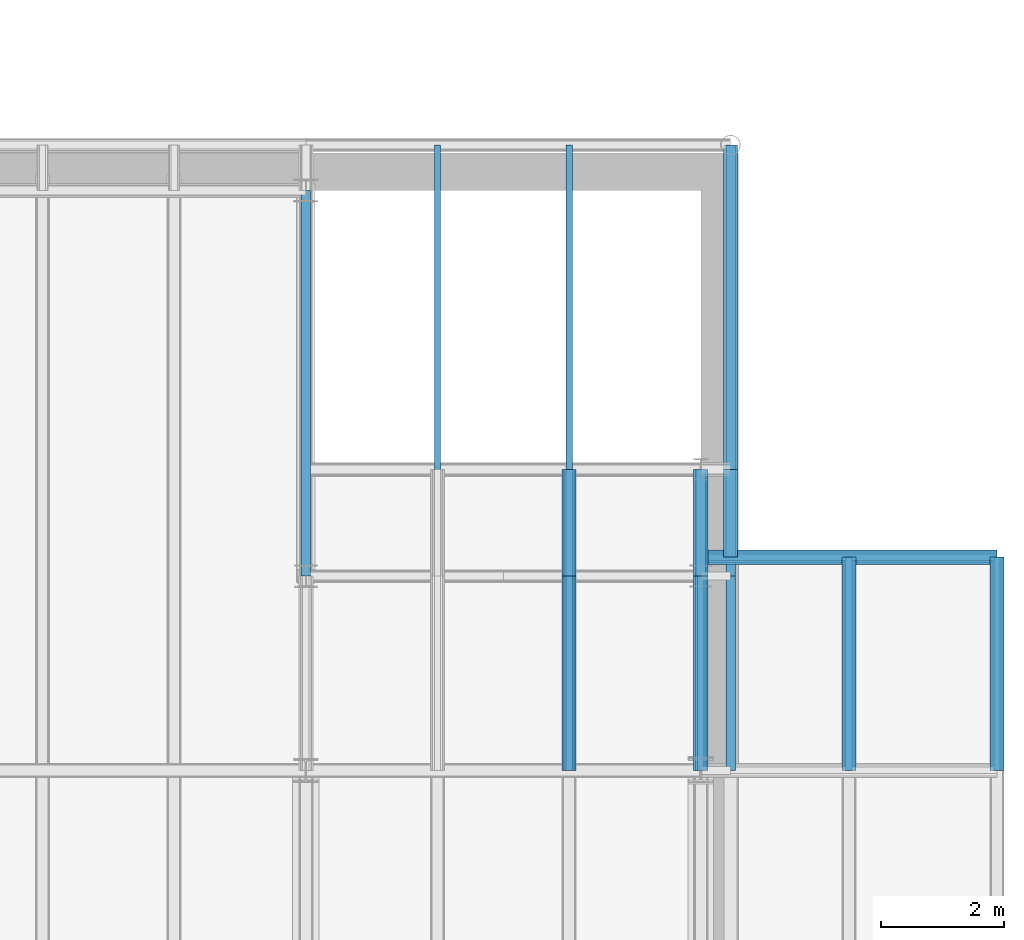
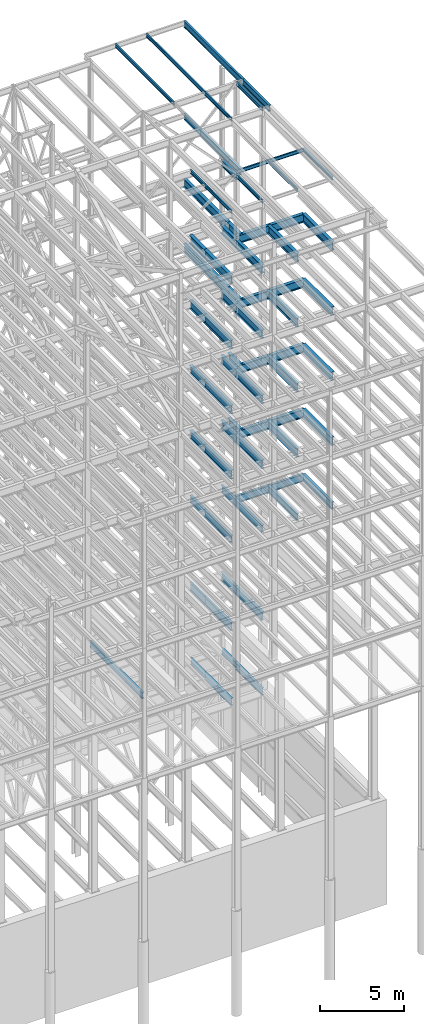
# One storey, part 147 of 150: 65 beams.
"""IFC2X3 building model written with IfcOpenShell, lengths in millimetres."""

import ifcopenshell
import ifcopenshell.guid

model = None  # the IFC model being written
_history = None  # IfcOwnerHistory: only IFC2X3 demands one
_inside = {}  # id of a spatial element -> (the spatial element, [elements in it])
_under = {}  # id of a project, library or spatial element -> (it, [spatial elements below it])
_declared = {}  # id of a project -> (the project, [libraries it declares])
_typed = {}  # id of a type object -> (the type object, [elements of that type])
_made_of = {}  # id of a material, layer set ... -> (it, [elements and type objects made of it])


def new_model(schema):
    """Start an empty IFC model of exactly this schema.

    Asked for "IFC4X3", IfcOpenShell would pick the latest addendum, in which some entities
    have other attributes; the version numbers below select the first issue.
    IFC2X3 requires an IfcOwnerHistory on every rooted entity: one is made here for all.
    """
    global model, _history
    if schema == "IFC4X3":
        model = ifcopenshell.file(schema_version=(4, 3, 0, 0))
    else:
        model = ifcopenshell.file(schema=schema)
    _inside.clear()
    _under.clear()
    _declared.clear()
    _typed.clear()
    _made_of.clear()
    _history = None
    if model.schema == "IFC2X3":
        org = make("IfcOrganization", Name="unknown")
        user = make(
            "IfcPersonAndOrganization",
            ThePerson=make("IfcPerson", FamilyName="unknown"),
            TheOrganization=org,
        )
        app = make(
            "IfcApplication",
            ApplicationDeveloper=org,
            Version="unknown",
            ApplicationFullName="unknown",
            ApplicationIdentifier="unknown",
        )
        _history = make(
            "IfcOwnerHistory",
            OwningUser=user,
            OwningApplication=app,
            ChangeAction="ADDED",
            CreationDate=0,
        )
    return model


def make(cls, **values):
    """One entity of the class cls with the attributes given. An attribute that is None is left unset."""
    return model.create_entity(
        cls, **{name: value for name, value in values.items() if value is not None}
    )


def rooted(cls, **values):
    """An entity with a GlobalId (a new one), such as an element, a storey or a relation."""
    return make(cls, GlobalId=ifcopenshell.guid.new(), OwnerHistory=_history, **values)


def si_unit(unit_type, name, prefix=None):
    """IfcSIUnit, for example si_unit("LENGTHUNIT", "METRE", prefix="MILLI")."""
    return make("IfcSIUnit", UnitType=unit_type, Prefix=prefix, Name=name)


def assignment(units):
    """IfcUnitAssignment: the units of a project."""
    return None if units is None else make("IfcUnitAssignment", Units=units)


def point(xyz):
    """IfcCartesianPoint."""
    return None if xyz is None else make("IfcCartesianPoint", Coordinates=xyz)


def direction(xyz):
    """IfcDirection."""
    return None if xyz is None else make("IfcDirection", DirectionRatios=xyz)


def frame(location, z_axis=None, x_axis=None):
    """IfcAxis2Placement3D, a coordinate frame: its origin and axes. An axis left out is left unset."""
    return make(
        "IfcAxis2Placement3D",
        Location=point(location),
        Axis=direction(z_axis),
        RefDirection=direction(x_axis),
    )


def frame_2d(location, x_axis=None):
    """IfcAxis2Placement2D, a coordinate frame in the plane: its origin and x axis."""
    return make(
        "IfcAxis2Placement2D", Location=point(location), RefDirection=direction(x_axis)
    )


def origin_with_axes():
    """The frame at (0, 0, 0) with the z axis (0, 0, 1) and the x axis (1, 0, 0) written out."""
    return frame((0.0, 0.0, 0.0), z_axis=(0.0, 0.0, 1.0), x_axis=(1.0, 0.0, 0.0))


def origin_2d_with_axis():
    """The frame at (0, 0) in the plane with the x axis (1, 0) written out."""
    return frame_2d((0.0, 0.0), x_axis=(1.0, 0.0))


def place(relative_to, where):
    """IfcLocalPlacement: puts the frame where relative to a parent placement (None: the world)."""
    return make(
        "IfcLocalPlacement", PlacementRelTo=relative_to, RelativePlacement=where
    )


def context(
    kind, dimensions, precision=None, world=None, true_north=None, identifier=None
):
    """IfcGeometricRepresentationContext, for example the 3D "Model" context."""
    return make(
        "IfcGeometricRepresentationContext",
        ContextIdentifier=identifier,
        ContextType=kind,
        CoordinateSpaceDimension=dimensions,
        Precision=precision,
        WorldCoordinateSystem=world,
        TrueNorth=true_north,
    )


def subcontext(parent, identifier, kind, view, scale=None):
    """IfcGeometricRepresentationSubContext, for example "Body" below "Model"."""
    return make(
        "IfcGeometricRepresentationSubContext",
        ContextIdentifier=identifier,
        ContextType=kind,
        ParentContext=parent,
        TargetScale=scale,
        TargetView=view,
    )


def project(units=None, contexts=None):
    """IfcProject with its units and contexts."""
    return rooted(
        "IfcProject",
        Name="project",
        RepresentationContexts=contexts,
        UnitsInContext=assignment(units),
    )


def spatial(cls, under=None, at=None, **own):
    """A site, building, storey or space (cls), placed at a placement, below another one or the project."""
    s = rooted(cls, ObjectPlacement=at, **own)
    if under is not None:
        _under.setdefault(under.id(), (under, []))[1].append(s)
    return s


def profile(cls, at=None, kind="AREA", **sizes):
    """A parametric profile (cls). Its sizes go by their IFC names, for example OverallWidth=200.0."""
    return make(cls, ProfileType=kind, Position=at, **sizes)


def i_section(**sizes):
    """IfcIShapeProfileDef."""
    return profile("IfcIShapeProfileDef", **sizes)


def extrude(swept, where, along, depth):
    """IfcExtrudedAreaSolid: the profile swept, set in the frame where, extruded along a direction by depth."""
    return make(
        "IfcExtrudedAreaSolid",
        SweptArea=swept,
        Position=where,
        ExtrudedDirection=direction(along),
        Depth=depth,
    )


def shape(context_of_items, identifier, shape_type, items):
    """IfcShapeRepresentation: the items that make up one representation, for example the "Body"."""
    return make(
        "IfcShapeRepresentation",
        ContextOfItems=context_of_items,
        RepresentationIdentifier=identifier,
        RepresentationType=shape_type,
        Items=items,
    )


def material(Name=None, Category=None):
    """IfcMaterial."""
    return make("IfcMaterial", Name=Name, Category=Category)


def made_of(thing, what):
    """Note that an element or type object is made of a material, layer set ...; save() writes the relation."""
    if what is not None:
        _made_of.setdefault(what.id(), (what, []))[1].append(thing)
    return thing


def type_object(cls, material=None, **own):
    """A type object (cls), such as IfcWallType, which elements share."""
    return made_of(rooted(cls, **own), material)


def element(
    cls,
    number,
    at=None,
    inside=None,
    cuts=None,
    type_object=None,
    material=None,
    context=None,
    identifier="Body",
    shape_type=None,
    held_by="IfcProductDefinitionShape",
    body=None,
    shapes=None,
    **own,
):
    """One element of the class cls, such as IfcWall. Its Tag is "e" and its number.

    at: its placement. inside: the storey or other place that contains it. cuts: it is an
    opening in that element (IfcRelVoidsElement). A single representation is given by context,
    identifier, shape_type and body (its items); several are given by shapes. held_by: the class
    of the entity that holds the representations. save() writes the other relations.
    """
    e = rooted(cls, Tag="e%d" % number, ObjectPlacement=at, **own)
    if body is not None:
        shapes = [shape(context, identifier, shape_type, body)]
    if shapes is not None:
        e.Representation = make(held_by, Representations=shapes)
    if inside is not None:
        _inside.setdefault(inside.id(), (inside, []))[1].append(e)
    if cuts is not None:
        rooted(
            "IfcRelVoidsElement", RelatingBuildingElement=cuts, RelatedOpeningElement=e
        )
    if type_object is not None:
        _typed.setdefault(type_object.id(), (type_object, []))[1].append(e)
    return made_of(e, material)


def aggregate(whole, parts):
    """IfcRelAggregates: a whole, such as a stair, and the parts it consists of."""
    return rooted("IfcRelAggregates", RelatingObject=whole, RelatedObjects=parts)


def save(model, path):
    """Write the relations noted so far, then the file.

    IfcRelAggregates (storeys below a building ...), IfcRelContainedInSpatialStructure (elements
    in a storey), IfcRelDefinesByType, IfcRelAssociatesMaterial and IfcRelDeclares: one each for
    every whole, place, type object, material and project.
    """
    for whole, parts in _under.values():
        aggregate(whole, parts)
    for where, things in _inside.values():
        rooted(
            "IfcRelContainedInSpatialStructure",
            RelatedElements=things,
            RelatingStructure=where,
        )
    for kind, things in _typed.values():
        rooted("IfcRelDefinesByType", RelatedObjects=things, RelatingType=kind)
    for what, things in _made_of.values():
        rooted("IfcRelAssociatesMaterial", RelatedObjects=things, RelatingMaterial=what)
    for by, libraries in _declared.values():
        rooted("IfcRelDeclares", RelatingContext=by, RelatedDefinitions=libraries)
    model.write(path)


model = new_model("IFC2X3")

# Units and contexts
model_context = context("Model", 3, precision=1e-05, world=origin_with_axes())
body_context = subcontext(model_context, "Body", "Model", "MODEL_VIEW")
ifc_project = project(units=[si_unit("LENGTHUNIT", "METRE", prefix="MILLI"), si_unit("AREAUNIT", "SQUARE_METRE"), si_unit("VOLUMEUNIT", "CUBIC_METRE"), si_unit("MASSUNIT", "GRAM", prefix="KILO"), si_unit("TIMEUNIT", "SECOND"), si_unit("PLANEANGLEUNIT", "RADIAN"), si_unit("SOLIDANGLEUNIT", "STERADIAN"), si_unit("THERMODYNAMICTEMPERATUREUNIT", "DEGREE_CELSIUS"), si_unit("LUMINOUSINTENSITYUNIT", "LUMEN")], contexts=[model_context])

# Site, building, storey
site_placement = place(None, origin_with_axes())
site = spatial("IfcSite", under=ifc_project, at=site_placement, CompositionType="ELEMENT")
building_placement = place(site_placement, origin_with_axes())
building = spatial("IfcBuilding", under=site, at=building_placement, Name="Undefined", CompositionType="ELEMENT")
storey_placement = place(building_placement, origin_with_axes())
storey = spatial("IfcBuildingStorey", under=building, at=storey_placement, Name="Undefined", CompositionType="ELEMENT", Elevation=0.0)

# Beams
ifc_material = material(Name="STEEL/A992")
beam_type_1 = type_object("IfcBeamType", Name="W18X35", PredefinedType="NOTDEFINED")
beam_1_placement = place(storey_placement, frame((89077.8, 25628.6, 65687.575), z_axis=(0.0, 0.0, 1.0), x_axis=(0.0, -1.0, 0.0)))
element("IfcBeam", 1, at=beam_1_placement, inside=storey, type_object=beam_type_1, material=ifc_material, Name="BEAM", ObjectType="W18X35", context=body_context, shape_type="SweptSolid", body=[
    extrude(i_section(OverallWidth=152.4, OverallDepth=450.85, WebThickness=7.9375, FlangeThickness=10.795, FilletRadius=17.78, at=origin_2d_with_axis()), frame((3149.59999999999, 0.0, 0.0), z_axis=(-1.0, 0.0, 0.0), x_axis=(0.0, -1.0, 0.0)), (0.0, 0.0, 1.0), 3149.59999999999),
])
beam_2_placement = place(storey_placement, frame((89077.8, 25628.6, 65687.575), z_axis=(0.0, 0.0, 1.0), x_axis=(0.0, 1.0, 0.0)))
element("IfcBeam", 2, at=beam_2_placement, inside=storey, type_object=beam_type_1, material=ifc_material, Name="BEAM", ObjectType="W18X35", context=body_context, shape_type="SweptSolid", body=[
    extrude(i_section(OverallWidth=152.4, OverallDepth=450.85, WebThickness=7.9375, FlangeThickness=10.795, FilletRadius=17.78, at=origin_2d_with_axis()), frame((6985.0, 0.0, 0.0), z_axis=(-1.0, 0.0, 0.0), x_axis=(0.0, -1.0, 0.0)), (0.0, 0.0, 1.0), 6985.0),
])
beam_3_placement = place(storey_placement, frame((88595.2, 25628.6, 58981.975), z_axis=(0.0, 0.0, 1.0), x_axis=(0.0, 1.0, 0.0)))
element("IfcBeam", 3, at=beam_3_placement, inside=storey, type_object=beam_type_1, material=ifc_material, Name="BEAM", ObjectType="W18X35", context=body_context, shape_type="SweptSolid", body=[
    extrude(i_section(OverallWidth=152.4, OverallDepth=450.85, WebThickness=7.9375, FlangeThickness=10.795, FilletRadius=17.78, at=origin_2d_with_axis()), frame((1727.2, 0.0, 0.0), z_axis=(-1.0, 0.0, 0.0), x_axis=(0.0, -1.0, 0.0)), (0.0, 0.0, 1.0), 1727.2),
])
beam_4_placement = place(storey_placement, frame((89077.8, 27355.8, 58981.975), z_axis=(0.0, 0.0, 1.0), x_axis=(0.0, -1.0, 0.0)))
element("IfcBeam", 4, at=beam_4_placement, inside=storey, type_object=beam_type_1, material=ifc_material, Name="BEAM", ObjectType="W18X35", context=body_context, shape_type="SweptSolid", body=[
    extrude(i_section(OverallWidth=152.4, OverallDepth=450.85, WebThickness=7.9375, FlangeThickness=10.795, FilletRadius=17.78, at=origin_2d_with_axis()), frame((1422.39999999999, 0.0, 0.0), z_axis=(-1.0, 0.0, 0.0), x_axis=(0.0, -1.0, 0.0)), (0.0, 0.0, 1.0), 1422.4),
])
beam_5_placement = place(storey_placement, frame((89077.8, 27355.8, 58981.975), z_axis=(0.0, 0.0, 1.0), x_axis=(0.0, 1.0, 0.0)))
element("IfcBeam", 5, at=beam_5_placement, inside=storey, type_object=beam_type_1, material=ifc_material, Name="BEAM", ObjectType="W18X35", context=body_context, shape_type="SweptSolid", body=[
    extrude(i_section(OverallWidth=152.4, OverallDepth=450.85, WebThickness=7.9375, FlangeThickness=10.795, FilletRadius=17.78, at=origin_2d_with_axis()), frame((5257.8, 0.0, 0.0), z_axis=(-1.0, 0.0, 0.0), x_axis=(0.0, -1.0, 0.0)), (0.0, 0.0, 1.0), 5257.8),
])
for number, where, z_axis, x_axis, name in (
    (6, (88595.2, 25628.6, 23548.975), (0.0, 0.0, 1.0), (0.0, 1.0, 0.0), "BEAM"),
    (7, (86461.6, 25628.6, 23548.975), (0.0, 0.0, 1.0), (0.0, 1.0, 0.0), "BEAM"),
):
    element("IfcBeam", number, at=place(storey_placement, frame(where, z_axis=z_axis, x_axis=x_axis)), inside=storey, type_object=beam_type_1, material=ifc_material, Name=name, ObjectType="W18X35", context=body_context, shape_type="SweptSolid", body=[
        extrude(i_section(OverallWidth=152.4, OverallDepth=450.85, WebThickness=7.9375, FlangeThickness=10.795, FilletRadius=17.78, at=origin_2d_with_axis()), frame((1727.2, 0.0, 0.0), z_axis=(-1.0, 0.0, 0.0), x_axis=(0.0, -1.0, 0.0)), (0.0, 0.0, 1.0), 1727.2),
    ])
beam_6_placement = place(storey_placement, frame((82194.4, 25628.6, 23548.975), z_axis=(0.0, 0.0, 1.0), x_axis=(0.0, 1.0, 0.0)))
element("IfcBeam", 8, at=beam_6_placement, inside=storey, type_object=beam_type_1, material=ifc_material, Name="BEAM", ObjectType="W18X35", context=body_context, shape_type="SweptSolid", body=[
    extrude(i_section(OverallWidth=152.4, OverallDepth=450.85, WebThickness=7.9375, FlangeThickness=10.795, FilletRadius=17.78, at=origin_2d_with_axis()), frame((6248.40000000001, 0.0, 0.0), z_axis=(-1.0, 0.0, 0.0), x_axis=(0.0, -1.0, 0.0)), (0.0, 0.0, 1.0), 6248.40000000001),
])
beam_type_2 = type_object("IfcBeamType", Name="W24X68", PredefinedType="NOTDEFINED")
for number, where, z_axis, x_axis, name in (
    (9, (88595.2, 25628.6, 54181.375), (0.0, 0.0, 1.0), (0.0, 1.0, 0.0), "BEAM"),
    (10, (86461.6, 25628.6, 54181.375), (0.0, 0.0, 1.0), (0.0, 1.0, 0.0), "BEAM"),
):
    element("IfcBeam", number, at=place(storey_placement, frame(where, z_axis=z_axis, x_axis=x_axis)), inside=storey, type_object=beam_type_2, material=ifc_material, Name=name, ObjectType="W24X68", context=body_context, shape_type="SweptSolid", body=[
        extrude(i_section(OverallWidth=227.838, OverallDepth=603.25, WebThickness=11.1125, FlangeThickness=14.859, FilletRadius=23.2409, at=origin_2d_with_axis()), frame((1727.2, 0.0, 0.0), z_axis=(-1.0, 0.0, 0.0), x_axis=(0.0, -1.0, 0.0)), (0.0, 0.0, 1.0), 1727.2),
    ])
beam_7_placement = place(storey_placement, frame((86461.6, 22479.0, 54181.375), z_axis=(0.0, 0.0, 1.0), x_axis=(0.0, 1.0, 0.0)))
element("IfcBeam", 11, at=beam_7_placement, inside=storey, type_object=beam_type_2, material=ifc_material, Name="BEAM", ObjectType="W24X68", context=body_context, shape_type="SweptSolid", body=[
    extrude(i_section(OverallWidth=227.838, OverallDepth=603.25, WebThickness=11.1125, FlangeThickness=14.859, FilletRadius=23.2409, at=origin_2d_with_axis()), frame((3149.59999999999, 0.0, 0.0), z_axis=(-1.0, 0.0, 0.0), x_axis=(0.0, -1.0, 0.0)), (0.0, 0.0, 1.0), 3149.6),
])
beam_8_placement = place(storey_placement, frame((89077.8, 27355.8, 54181.375), z_axis=(0.0, 0.0, 1.0), x_axis=(0.0, 1.0, 0.0)))
element("IfcBeam", 12, at=beam_8_placement, inside=storey, type_object=beam_type_2, material=ifc_material, Name="BEAM", ObjectType="W24X68", context=body_context, shape_type="SweptSolid", body=[
    extrude(i_section(OverallWidth=227.838, OverallDepth=603.25, WebThickness=11.1125, FlangeThickness=14.859, FilletRadius=23.2409, at=origin_2d_with_axis()), frame((5257.8, 0.0, 0.0), z_axis=(-1.0, 0.0, 0.0), x_axis=(0.0, -1.0, 0.0)), (0.0, 0.0, 1.0), 5257.8),
])
beam_9_placement = place(storey_placement, frame((89077.8, 25933.4, 54181.375), z_axis=(0.0, 0.0, 1.0), x_axis=(0.0, 1.0, 0.0)))
element("IfcBeam", 13, at=beam_9_placement, inside=storey, type_object=beam_type_2, material=ifc_material, Name="BEAM", ObjectType="W24X68", context=body_context, shape_type="SweptSolid", body=[
    extrude(i_section(OverallWidth=227.838, OverallDepth=603.25, WebThickness=11.1125, FlangeThickness=14.859, FilletRadius=23.2409, at=origin_2d_with_axis()), frame((1422.39999999999, 0.0, 0.0), z_axis=(-1.0, 0.0, 0.0), x_axis=(0.0, -1.0, 0.0)), (0.0, 0.0, 1.0), 1422.4),
])
beam_10_placement = place(storey_placement, frame((93395.8, 22479.0, 54181.375), z_axis=(0.0, 0.0, 1.0), x_axis=(0.0, 1.0, 0.0)))
element("IfcBeam", 14, at=beam_10_placement, inside=storey, type_object=beam_type_2, material=ifc_material, Name="BEAM", ObjectType="W24X68", context=body_context, shape_type="SweptSolid", body=[
    extrude(i_section(OverallWidth=227.838, OverallDepth=603.25, WebThickness=11.1125, FlangeThickness=14.859, FilletRadius=23.2409, at=origin_2d_with_axis()), frame((3454.4, 0.0, 0.0), z_axis=(-1.0, 0.0, 0.0), x_axis=(0.0, -1.0, 0.0)), (0.0, 0.0, 1.0), 3454.39999999999),
])
beam_11_placement = place(storey_placement, frame((88595.2, 25933.4, 54181.375), z_axis=(0.0, 0.0, 1.0), x_axis=(1.0, 0.0, 0.0)))
element("IfcBeam", 15, at=beam_11_placement, inside=storey, type_object=beam_type_2, material=ifc_material, Name="BEAM", ObjectType="W24X68", context=body_context, shape_type="SweptSolid", body=[
    extrude(i_section(OverallWidth=227.838, OverallDepth=603.25, WebThickness=11.1125, FlangeThickness=14.859, FilletRadius=23.2409, at=origin_2d_with_axis()), frame((4800.60000000001, 0.0, 0.0), z_axis=(-1.0, 0.0, 0.0), x_axis=(0.0, -1.0, 0.0)), (0.0, 0.0, 1.0), 4800.60000000001),
])
beam_12_placement = place(storey_placement, frame((90995.5, 22479.0, 54181.375), z_axis=(0.0, 0.0, 1.0), x_axis=(0.0, 1.0, 0.0)))
element("IfcBeam", 16, at=beam_12_placement, inside=storey, type_object=beam_type_2, material=ifc_material, Name="BEAM", ObjectType="W24X68", context=body_context, shape_type="SweptSolid", body=[
    extrude(i_section(OverallWidth=227.838, OverallDepth=603.25, WebThickness=11.1125, FlangeThickness=14.859, FilletRadius=23.2409, at=origin_2d_with_axis()), frame((3454.39965456, 0.0, 0.0), z_axis=(-1.0, 0.0, 0.0), x_axis=(0.0, -1.0, 0.0)), (0.0, 0.0, 1.0), 3454.39965456),
])
beam_13_placement = place(storey_placement, frame((88595.2, 22479.0, 54181.375), z_axis=(0.0, 0.0, 1.0), x_axis=(0.0, 1.0, 0.0)))
element("IfcBeam", 17, at=beam_13_placement, inside=storey, type_object=beam_type_2, material=ifc_material, Name="BEAM", ObjectType="W24X68", context=body_context, shape_type="SweptSolid", body=[
    extrude(i_section(OverallWidth=227.838, OverallDepth=603.25, WebThickness=11.1125, FlangeThickness=14.859, FilletRadius=23.2409, at=origin_2d_with_axis()), frame((3149.59968503999, 0.0, 0.0), z_axis=(-1.0, 0.0, 0.0), x_axis=(0.0, -1.0, 0.0)), (0.0, 0.0, 1.0), 3149.59968503999),
])
for number, where, z_axis, x_axis, name in (
    (18, (88595.2, 25628.6, 49456.975), (0.0, 0.0, 1.0), (0.0, 1.0, 0.0), "BEAM"),
    (19, (86461.6, 25628.6, 49456.975), (0.0, 0.0, 1.0), (0.0, 1.0, 0.0), "BEAM"),
):
    element("IfcBeam", number, at=place(storey_placement, frame(where, z_axis=z_axis, x_axis=x_axis)), inside=storey, type_object=beam_type_2, material=ifc_material, Name=name, ObjectType="W24X68", context=body_context, shape_type="SweptSolid", body=[
        extrude(i_section(OverallWidth=227.838, OverallDepth=603.25, WebThickness=11.1125, FlangeThickness=14.859, FilletRadius=23.2409, at=origin_2d_with_axis()), frame((1727.2, 0.0, 0.0), z_axis=(-1.0, 0.0, 0.0), x_axis=(0.0, -1.0, 0.0)), (0.0, 0.0, 1.0), 1727.2),
    ])
beam_14_placement = place(storey_placement, frame((86461.6, 22479.0, 49456.975), z_axis=(0.0, 0.0, 1.0), x_axis=(0.0, 1.0, 0.0)))
element("IfcBeam", 20, at=beam_14_placement, inside=storey, type_object=beam_type_2, material=ifc_material, Name="BEAM", ObjectType="W24X68", context=body_context, shape_type="SweptSolid", body=[
    extrude(i_section(OverallWidth=227.838, OverallDepth=603.25, WebThickness=11.1125, FlangeThickness=14.859, FilletRadius=23.2409, at=origin_2d_with_axis()), frame((3149.59999999999, 0.0, 0.0), z_axis=(-1.0, 0.0, 0.0), x_axis=(0.0, -1.0, 0.0)), (0.0, 0.0, 1.0), 3149.6),
])
beam_15_placement = place(storey_placement, frame((89077.8, 27355.8, 49456.975), z_axis=(0.0, 0.0, 1.0), x_axis=(0.0, 1.0, 0.0)))
element("IfcBeam", 21, at=beam_15_placement, inside=storey, type_object=beam_type_2, material=ifc_material, Name="BEAM", ObjectType="W24X68", context=body_context, shape_type="SweptSolid", body=[
    extrude(i_section(OverallWidth=227.838, OverallDepth=603.25, WebThickness=11.1125, FlangeThickness=14.859, FilletRadius=23.2409, at=origin_2d_with_axis()), frame((5257.8, 0.0, 0.0), z_axis=(-1.0, 0.0, 0.0), x_axis=(0.0, -1.0, 0.0)), (0.0, 0.0, 1.0), 5257.8),
])
beam_16_placement = place(storey_placement, frame((89077.8, 25933.4, 49456.975), z_axis=(0.0, 0.0, 1.0), x_axis=(0.0, 1.0, 0.0)))
element("IfcBeam", 22, at=beam_16_placement, inside=storey, type_object=beam_type_2, material=ifc_material, Name="BEAM", ObjectType="W24X68", context=body_context, shape_type="SweptSolid", body=[
    extrude(i_section(OverallWidth=227.838, OverallDepth=603.25, WebThickness=11.1125, FlangeThickness=14.859, FilletRadius=23.2409, at=origin_2d_with_axis()), frame((1422.39999999999, 0.0, 0.0), z_axis=(-1.0, 0.0, 0.0), x_axis=(0.0, -1.0, 0.0)), (0.0, 0.0, 1.0), 1422.4),
])
beam_17_placement = place(storey_placement, frame((93395.8, 22479.0, 49456.975), z_axis=(0.0, 0.0, 1.0), x_axis=(0.0, 1.0, 0.0)))
element("IfcBeam", 23, at=beam_17_placement, inside=storey, type_object=beam_type_2, material=ifc_material, Name="BEAM", ObjectType="W24X68", context=body_context, shape_type="SweptSolid", body=[
    extrude(i_section(OverallWidth=227.838, OverallDepth=603.25, WebThickness=11.1125, FlangeThickness=14.859, FilletRadius=23.2409, at=origin_2d_with_axis()), frame((3454.4, 0.0, 0.0), z_axis=(-1.0, 0.0, 0.0), x_axis=(0.0, -1.0, 0.0)), (0.0, 0.0, 1.0), 3454.39999999999),
])
beam_18_placement = place(storey_placement, frame((88595.2, 25933.4, 49456.975), z_axis=(0.0, 0.0, 1.0), x_axis=(1.0, 0.0, 0.0)))
element("IfcBeam", 24, at=beam_18_placement, inside=storey, type_object=beam_type_2, material=ifc_material, Name="BEAM", ObjectType="W24X68", context=body_context, shape_type="SweptSolid", body=[
    extrude(i_section(OverallWidth=227.838, OverallDepth=603.25, WebThickness=11.1125, FlangeThickness=14.859, FilletRadius=23.2409, at=origin_2d_with_axis()), frame((4800.60000000001, 0.0, 0.0), z_axis=(-1.0, 0.0, 0.0), x_axis=(0.0, -1.0, 0.0)), (0.0, 0.0, 1.0), 4800.60000000001),
])
beam_19_placement = place(storey_placement, frame((90995.5, 22479.0, 49456.975), z_axis=(0.0, 0.0, 1.0), x_axis=(0.0, 1.0, 0.0)))
element("IfcBeam", 25, at=beam_19_placement, inside=storey, type_object=beam_type_2, material=ifc_material, Name="BEAM", ObjectType="W24X68", context=body_context, shape_type="SweptSolid", body=[
    extrude(i_section(OverallWidth=227.838, OverallDepth=603.25, WebThickness=11.1125, FlangeThickness=14.859, FilletRadius=23.2409, at=origin_2d_with_axis()), frame((3454.39965456, 0.0, 0.0), z_axis=(-1.0, 0.0, 0.0), x_axis=(0.0, -1.0, 0.0)), (0.0, 0.0, 1.0), 3454.39965456),
])
beam_20_placement = place(storey_placement, frame((88595.2, 22479.0, 49456.975), z_axis=(0.0, 0.0, 1.0), x_axis=(0.0, 1.0, 0.0)))
element("IfcBeam", 26, at=beam_20_placement, inside=storey, type_object=beam_type_2, material=ifc_material, Name="BEAM", ObjectType="W24X68", context=body_context, shape_type="SweptSolid", body=[
    extrude(i_section(OverallWidth=227.838, OverallDepth=603.25, WebThickness=11.1125, FlangeThickness=14.859, FilletRadius=23.2409, at=origin_2d_with_axis()), frame((3149.59968503999, 0.0, 0.0), z_axis=(-1.0, 0.0, 0.0), x_axis=(0.0, -1.0, 0.0)), (0.0, 0.0, 1.0), 3149.59968503999),
])
for number, where, z_axis, x_axis, name in (
    (27, (88595.2, 25628.6, 44732.575), (0.0, 0.0, 1.0), (0.0, 1.0, 0.0), "BEAM"),
    (28, (86461.6, 25628.6, 44732.575), (0.0, 0.0, 1.0), (0.0, 1.0, 0.0), "BEAM"),
):
    element("IfcBeam", number, at=place(storey_placement, frame(where, z_axis=z_axis, x_axis=x_axis)), inside=storey, type_object=beam_type_2, material=ifc_material, Name=name, ObjectType="W24X68", context=body_context, shape_type="SweptSolid", body=[
        extrude(i_section(OverallWidth=227.838, OverallDepth=603.25, WebThickness=11.1125, FlangeThickness=14.859, FilletRadius=23.2409, at=origin_2d_with_axis()), frame((1727.2, 0.0, 0.0), z_axis=(-1.0, 0.0, 0.0), x_axis=(0.0, -1.0, 0.0)), (0.0, 0.0, 1.0), 1727.2),
    ])
beam_21_placement = place(storey_placement, frame((86461.6, 22479.0, 44732.575), z_axis=(0.0, 0.0, 1.0), x_axis=(0.0, 1.0, 0.0)))
element("IfcBeam", 29, at=beam_21_placement, inside=storey, type_object=beam_type_2, material=ifc_material, Name="BEAM", ObjectType="W24X68", context=body_context, shape_type="SweptSolid", body=[
    extrude(i_section(OverallWidth=227.838, OverallDepth=603.25, WebThickness=11.1125, FlangeThickness=14.859, FilletRadius=23.2409, at=origin_2d_with_axis()), frame((3149.59999999999, 0.0, 0.0), z_axis=(-1.0, 0.0, 0.0), x_axis=(0.0, -1.0, 0.0)), (0.0, 0.0, 1.0), 3149.6),
])
beam_22_placement = place(storey_placement, frame((89077.8, 25933.4, 44732.575), z_axis=(0.0, 0.0, 1.0), x_axis=(0.0, 1.0, 0.0)))
element("IfcBeam", 30, at=beam_22_placement, inside=storey, type_object=beam_type_2, material=ifc_material, Name="BEAM", ObjectType="W24X68", context=body_context, shape_type="SweptSolid", body=[
    extrude(i_section(OverallWidth=227.838, OverallDepth=603.25, WebThickness=11.1125, FlangeThickness=14.859, FilletRadius=23.2409, at=origin_2d_with_axis()), frame((1422.39999999999, 0.0, 0.0), z_axis=(-1.0, 0.0, 0.0), x_axis=(0.0, -1.0, 0.0)), (0.0, 0.0, 1.0), 1422.4),
])
beam_23_placement = place(storey_placement, frame((93395.8, 22479.0, 44732.575), z_axis=(0.0, 0.0, 1.0), x_axis=(0.0, 1.0, 0.0)))
element("IfcBeam", 31, at=beam_23_placement, inside=storey, type_object=beam_type_2, material=ifc_material, Name="BEAM", ObjectType="W24X68", context=body_context, shape_type="SweptSolid", body=[
    extrude(i_section(OverallWidth=227.838, OverallDepth=603.25, WebThickness=11.1125, FlangeThickness=14.859, FilletRadius=23.2409, at=origin_2d_with_axis()), frame((3454.4, 0.0, 0.0), z_axis=(-1.0, 0.0, 0.0), x_axis=(0.0, -1.0, 0.0)), (0.0, 0.0, 1.0), 3454.39999999999),
])
beam_24_placement = place(storey_placement, frame((88595.2, 25933.4, 44732.575), z_axis=(0.0, 0.0, 1.0), x_axis=(1.0, 0.0, 0.0)))
element("IfcBeam", 32, at=beam_24_placement, inside=storey, type_object=beam_type_2, material=ifc_material, Name="BEAM", ObjectType="W24X68", context=body_context, shape_type="SweptSolid", body=[
    extrude(i_section(OverallWidth=227.838, OverallDepth=603.25, WebThickness=11.1125, FlangeThickness=14.859, FilletRadius=23.2409, at=origin_2d_with_axis()), frame((4800.60000000001, 0.0, 0.0), z_axis=(-1.0, 0.0, 0.0), x_axis=(0.0, -1.0, 0.0)), (0.0, 0.0, 1.0), 4800.60000000001),
])
beam_25_placement = place(storey_placement, frame((90995.5, 22479.0, 44732.575), z_axis=(0.0, 0.0, 1.0), x_axis=(0.0, 1.0, 0.0)))
element("IfcBeam", 33, at=beam_25_placement, inside=storey, type_object=beam_type_2, material=ifc_material, Name="BEAM", ObjectType="W24X68", context=body_context, shape_type="SweptSolid", body=[
    extrude(i_section(OverallWidth=227.838, OverallDepth=603.25, WebThickness=11.1125, FlangeThickness=14.859, FilletRadius=23.2409, at=origin_2d_with_axis()), frame((3454.39965456, 0.0, 0.0), z_axis=(-1.0, 0.0, 0.0), x_axis=(0.0, -1.0, 0.0)), (0.0, 0.0, 1.0), 3454.39965456),
])
beam_26_placement = place(storey_placement, frame((88595.2, 22479.0, 44732.575), z_axis=(0.0, 0.0, 1.0), x_axis=(0.0, 1.0, 0.0)))
element("IfcBeam", 34, at=beam_26_placement, inside=storey, type_object=beam_type_2, material=ifc_material, Name="BEAM", ObjectType="W24X68", context=body_context, shape_type="SweptSolid", body=[
    extrude(i_section(OverallWidth=227.838, OverallDepth=603.25, WebThickness=11.1125, FlangeThickness=14.859, FilletRadius=23.2409, at=origin_2d_with_axis()), frame((3149.59968503999, 0.0, 0.0), z_axis=(-1.0, 0.0, 0.0), x_axis=(0.0, -1.0, 0.0)), (0.0, 0.0, 1.0), 3149.59968503999),
])
for number, where, z_axis, x_axis, name in (
    (35, (88595.2, 25628.6, 40008.175), (0.0, 0.0, 1.0), (0.0, 1.0, 0.0), "BEAM"),
    (36, (86461.6, 25628.6, 40008.175), (0.0, 0.0, 1.0), (0.0, 1.0, 0.0), "BEAM"),
):
    element("IfcBeam", number, at=place(storey_placement, frame(where, z_axis=z_axis, x_axis=x_axis)), inside=storey, type_object=beam_type_2, material=ifc_material, Name=name, ObjectType="W24X68", context=body_context, shape_type="SweptSolid", body=[
        extrude(i_section(OverallWidth=227.838, OverallDepth=603.25, WebThickness=11.1125, FlangeThickness=14.859, FilletRadius=23.2409, at=origin_2d_with_axis()), frame((1727.2, 0.0, 0.0), z_axis=(-1.0, 0.0, 0.0), x_axis=(0.0, -1.0, 0.0)), (0.0, 0.0, 1.0), 1727.2),
    ])
beam_27_placement = place(storey_placement, frame((86461.6, 22479.0, 40008.175), z_axis=(0.0, 0.0, 1.0), x_axis=(0.0, 1.0, 0.0)))
element("IfcBeam", 37, at=beam_27_placement, inside=storey, type_object=beam_type_2, material=ifc_material, Name="BEAM", ObjectType="W24X68", context=body_context, shape_type="SweptSolid", body=[
    extrude(i_section(OverallWidth=227.838, OverallDepth=603.25, WebThickness=11.1125, FlangeThickness=14.859, FilletRadius=23.2409, at=origin_2d_with_axis()), frame((3149.59999999999, 0.0, 0.0), z_axis=(-1.0, 0.0, 0.0), x_axis=(0.0, -1.0, 0.0)), (0.0, 0.0, 1.0), 3149.6),
])
beam_28_placement = place(storey_placement, frame((89077.8, 25933.4, 40008.175), z_axis=(0.0, 0.0, 1.0), x_axis=(0.0, 1.0, 0.0)))
element("IfcBeam", 38, at=beam_28_placement, inside=storey, type_object=beam_type_2, material=ifc_material, Name="BEAM", ObjectType="W24X68", context=body_context, shape_type="SweptSolid", body=[
    extrude(i_section(OverallWidth=227.838, OverallDepth=603.25, WebThickness=11.1125, FlangeThickness=14.859, FilletRadius=23.2409, at=origin_2d_with_axis()), frame((1422.39999999999, 0.0, 0.0), z_axis=(-1.0, 0.0, 0.0), x_axis=(0.0, -1.0, 0.0)), (0.0, 0.0, 1.0), 1422.4),
])
beam_29_placement = place(storey_placement, frame((93395.8, 22479.0, 40008.175), z_axis=(0.0, 0.0, 1.0), x_axis=(0.0, 1.0, 0.0)))
element("IfcBeam", 39, at=beam_29_placement, inside=storey, type_object=beam_type_2, material=ifc_material, Name="BEAM", ObjectType="W24X68", context=body_context, shape_type="SweptSolid", body=[
    extrude(i_section(OverallWidth=227.838, OverallDepth=603.25, WebThickness=11.1125, FlangeThickness=14.859, FilletRadius=23.2409, at=origin_2d_with_axis()), frame((3454.4, 0.0, 0.0), z_axis=(-1.0, 0.0, 0.0), x_axis=(0.0, -1.0, 0.0)), (0.0, 0.0, 1.0), 3454.39999999999),
])
beam_30_placement = place(storey_placement, frame((88595.2, 25933.4, 40008.175), z_axis=(0.0, 0.0, 1.0), x_axis=(1.0, 0.0, 0.0)))
element("IfcBeam", 40, at=beam_30_placement, inside=storey, type_object=beam_type_2, material=ifc_material, Name="BEAM", ObjectType="W24X68", context=body_context, shape_type="SweptSolid", body=[
    extrude(i_section(OverallWidth=227.838, OverallDepth=603.25, WebThickness=11.1125, FlangeThickness=14.859, FilletRadius=23.2409, at=origin_2d_with_axis()), frame((4800.60000000001, 0.0, 0.0), z_axis=(-1.0, 0.0, 0.0), x_axis=(0.0, -1.0, 0.0)), (0.0, 0.0, 1.0), 4800.60000000001),
])
beam_31_placement = place(storey_placement, frame((90995.5, 22479.0, 40008.175), z_axis=(0.0, 0.0, 1.0), x_axis=(0.0, 1.0, 0.0)))
element("IfcBeam", 41, at=beam_31_placement, inside=storey, type_object=beam_type_2, material=ifc_material, Name="BEAM", ObjectType="W24X68", context=body_context, shape_type="SweptSolid", body=[
    extrude(i_section(OverallWidth=227.838, OverallDepth=603.25, WebThickness=11.1125, FlangeThickness=14.859, FilletRadius=23.2409, at=origin_2d_with_axis()), frame((3454.39965456, 0.0, 0.0), z_axis=(-1.0, 0.0, 0.0), x_axis=(0.0, -1.0, 0.0)), (0.0, 0.0, 1.0), 3454.39965456),
])
beam_32_placement = place(storey_placement, frame((88595.2, 22479.0, 40008.175), z_axis=(0.0, 0.0, 1.0), x_axis=(0.0, 1.0, 0.0)))
element("IfcBeam", 42, at=beam_32_placement, inside=storey, type_object=beam_type_2, material=ifc_material, Name="BEAM", ObjectType="W24X68", context=body_context, shape_type="SweptSolid", body=[
    extrude(i_section(OverallWidth=227.838, OverallDepth=603.25, WebThickness=11.1125, FlangeThickness=14.859, FilletRadius=23.2409, at=origin_2d_with_axis()), frame((3149.59999999999, 0.0, 0.0), z_axis=(-1.0, 0.0, 0.0), x_axis=(0.0, -1.0, 0.0)), (0.0, 0.0, 1.0), 3149.59999999999),
])
beam_type_3 = type_object("IfcBeamType", Name="W10X15", PredefinedType="NOTDEFINED")
for number, where, z_axis, x_axis, name in (
    (43, (86461.6, 25628.6, 65786.0), (0.0, 0.0, 1.0), (0.0, 1.0, 0.0), "BEAM"),
    (44, (84328.0, 25628.6, 65786.0), (0.0, 0.0, 1.0), (0.0, 1.0, 0.0), "BEAM"),
):
    element("IfcBeam", number, at=place(storey_placement, frame(where, z_axis=z_axis, x_axis=x_axis)), inside=storey, type_object=beam_type_3, material=ifc_material, Name=name, ObjectType="W10X15", context=body_context, shape_type="SweptSolid", body=[
        extrude(i_section(OverallWidth=101.6, OverallDepth=254.0, WebThickness=6.3499, FlangeThickness=6.858, FilletRadius=13.7795, at=origin_2d_with_axis()), frame((6985.0, 0.0, 0.0), z_axis=(-1.0, 0.0, 0.0), x_axis=(0.0, -1.0, 0.0)), (0.0, 0.0, 1.0), 6985.0),
    ])
for number, where, z_axis, x_axis, name in (
    (45, (88595.2, 22479.0, 65786.0), (0.0, 0.0, 1.0), (0.0, 1.0, 0.0), "BEAM"),
    (46, (86461.6, 22479.0, 65786.0), (0.0, 0.0, 1.0), (0.0, 1.0, 0.0), "BEAM"),
):
    element("IfcBeam", number, at=place(storey_placement, frame(where, z_axis=z_axis, x_axis=x_axis)), inside=storey, type_object=beam_type_3, material=ifc_material, Name=name, ObjectType="W10X15", context=body_context, shape_type="SweptSolid", body=[
        extrude(i_section(OverallWidth=101.6, OverallDepth=254.0, WebThickness=6.3499, FlangeThickness=6.858, FilletRadius=13.7795, at=origin_2d_with_axis()), frame((3149.59999999999, 0.0, 0.0), z_axis=(-1.0, 0.0, 0.0), x_axis=(0.0, -1.0, 0.0)), (0.0, 0.0, 1.0), 3149.6),
    ])
for number, where, z_axis, x_axis, name in (
    (47, (93395.8, 22479.0, 59080.4), (0.0, 0.0, 1.0), (0.0, 1.0, 0.0), "BEAM"),
    (48, (90995.5, 22479.0, 59080.4), (0.0, 0.0, 1.0), (0.0, 1.0, 0.0), "BEAM"),
):
    element("IfcBeam", number, at=place(storey_placement, frame(where, z_axis=z_axis, x_axis=x_axis)), inside=storey, type_object=beam_type_3, material=ifc_material, Name=name, ObjectType="W10X15", context=body_context, shape_type="SweptSolid", body=[
        extrude(i_section(OverallWidth=101.6, OverallDepth=254.0, WebThickness=6.3499, FlangeThickness=6.858, FilletRadius=13.7795, at=origin_2d_with_axis()), frame((3454.4, 0.0, 0.0), z_axis=(-1.0, 0.0, 0.0), x_axis=(0.0, -1.0, 0.0)), (0.0, 0.0, 1.0), 3454.4),
    ])
beam_33_placement = place(storey_placement, frame((88595.2, 25933.4, 59080.4), z_axis=(0.0, 0.0, 1.0), x_axis=(1.0, 0.0, 0.0)))
element("IfcBeam", 49, at=beam_33_placement, inside=storey, type_object=beam_type_3, material=ifc_material, Name="BEAM", ObjectType="W10X15", context=body_context, shape_type="SweptSolid", body=[
    extrude(i_section(OverallWidth=101.6, OverallDepth=254.0, WebThickness=6.3499, FlangeThickness=6.858, FilletRadius=13.7795, at=origin_2d_with_axis()), frame((4800.60000000001, 0.0, 0.0), z_axis=(-1.0, 0.0, 0.0), x_axis=(0.0, -1.0, 0.0)), (0.0, 0.0, 1.0), 4800.60000000001),
])
beam_34_placement = place(storey_placement, frame((86461.6, 25628.6, 59080.4), z_axis=(0.0, 0.0, 1.0), x_axis=(0.0, 1.0, 0.0)))
element("IfcBeam", 50, at=beam_34_placement, inside=storey, type_object=beam_type_3, material=ifc_material, Name="BEAM", ObjectType="W10X15", context=body_context, shape_type="SweptSolid", body=[
    extrude(i_section(OverallWidth=101.6, OverallDepth=254.0, WebThickness=6.3499, FlangeThickness=6.858, FilletRadius=13.7795, at=origin_2d_with_axis()), frame((1727.2, 0.0, 0.0), z_axis=(-1.0, 0.0, 0.0), x_axis=(0.0, -1.0, 0.0)), (0.0, 0.0, 1.0), 1727.2),
])
for number, where, z_axis, x_axis, name in (
    (51, (88595.2, 22479.0, 59080.4), (0.0, 0.0, 1.0), (0.0, 1.0, 0.0), "BEAM"),
    (52, (86461.6, 22479.0, 59080.4), (0.0, 0.0, 1.0), (0.0, 1.0, 0.0), "BEAM"),
):
    element("IfcBeam", number, at=place(storey_placement, frame(where, z_axis=z_axis, x_axis=x_axis)), inside=storey, type_object=beam_type_3, material=ifc_material, Name=name, ObjectType="W10X15", context=body_context, shape_type="SweptSolid", body=[
        extrude(i_section(OverallWidth=101.6, OverallDepth=254.0, WebThickness=6.3499, FlangeThickness=6.858, FilletRadius=13.7795, at=origin_2d_with_axis()), frame((3149.59999999999, 0.0, 0.0), z_axis=(-1.0, 0.0, 0.0), x_axis=(0.0, -1.0, 0.0)), (0.0, 0.0, 1.0), 3149.6),
    ])
beam_type_4 = type_object("IfcBeamType", Name="W24X55", PredefinedType="NOTDEFINED")
beam_35_placement = place(storey_placement, frame((86461.6, 25628.59968504, 28986.1625), z_axis=(0.0, 0.0, 1.0), x_axis=(0.0, 1.0, 0.0)))
element("IfcBeam", 53, at=beam_35_placement, inside=storey, type_object=beam_type_4, material=ifc_material, Name="BEAM", ObjectType="W24X55", context=body_context, shape_type="SweptSolid", body=[
    extrude(i_section(OverallWidth=178.054, OverallDepth=600.075, WebThickness=9.5249, FlangeThickness=12.827, FilletRadius=23.6854, at=origin_2d_with_axis()), frame((1727.20031496001, 0.0, 0.0), z_axis=(-1.0, 0.0, 0.0), x_axis=(0.0, -1.0, 0.0)), (0.0, 0.0, 1.0), 1727.20031496),
])
beam_36_placement = place(storey_placement, frame((86461.6, 22479.0, 28986.1625), z_axis=(0.0, 0.0, 1.0), x_axis=(0.0, 1.0, 0.0)))
element("IfcBeam", 54, at=beam_36_placement, inside=storey, type_object=beam_type_4, material=ifc_material, Name="BEAM", ObjectType="W24X55", context=body_context, shape_type="SweptSolid", body=[
    extrude(i_section(OverallWidth=178.054, OverallDepth=600.075, WebThickness=9.5249, FlangeThickness=12.827, FilletRadius=23.6854, at=origin_2d_with_axis()), frame((3149.59968503999, 0.0, 0.0), z_axis=(-1.0, 0.0, 0.0), x_axis=(0.0, -1.0, 0.0)), (0.0, 0.0, 1.0), 3149.59968503999),
])
beam_37_placement = place(storey_placement, frame((88595.2, 25628.6, 28986.1625), z_axis=(0.0, 0.0, 1.0), x_axis=(0.0, 1.0, 0.0)))
element("IfcBeam", 55, at=beam_37_placement, inside=storey, type_object=beam_type_4, material=ifc_material, Name="BEAM", ObjectType="W24X55", context=body_context, shape_type="SweptSolid", body=[
    extrude(i_section(OverallWidth=178.054, OverallDepth=600.075, WebThickness=9.5249, FlangeThickness=12.827, FilletRadius=23.6854, at=origin_2d_with_axis()), frame((1727.2, 0.0, 0.0), z_axis=(-1.0, 0.0, 0.0), x_axis=(0.0, -1.0, 0.0)), (0.0, 0.0, 1.0), 1727.2),
])
beam_38_placement = place(storey_placement, frame((88595.2, 22479.0, 28986.1625), z_axis=(0.0, 0.0, 1.0), x_axis=(0.0, 1.0, 0.0)))
element("IfcBeam", 56, at=beam_38_placement, inside=storey, type_object=beam_type_4, material=ifc_material, Name="BEAM", ObjectType="W24X55", context=body_context, shape_type="SweptSolid", body=[
    extrude(i_section(OverallWidth=178.054, OverallDepth=600.075, WebThickness=9.5249, FlangeThickness=12.827, FilletRadius=23.6854, at=origin_2d_with_axis()), frame((3149.59999999999, 0.0, 0.0), z_axis=(-1.0, 0.0, 0.0), x_axis=(0.0, -1.0, 0.0)), (0.0, 0.0, 1.0), 3149.59999999999),
])
beam_type_5 = type_object("IfcBeamType", Name="W21X44", PredefinedType="NOTDEFINED")
beam_39_placement = place(storey_placement, frame((86461.59935992, 25628.59968504, 35323.4625), z_axis=(0.0, 0.0, 1.0), x_axis=(0.0, 1.0, 0.0)))
element("IfcBeam", 57, at=beam_39_placement, inside=storey, type_object=beam_type_5, material=ifc_material, Name="BEAM", ObjectType="W21X44", context=body_context, shape_type="SweptSolid", body=[
    extrude(i_section(OverallWidth=165.1, OverallDepth=523.875, WebThickness=9.5249, FlangeThickness=11.43, FilletRadius=17.145, at=origin_2d_with_axis()), frame((1727.20031496001, 0.0, 0.0), z_axis=(-1.0, 0.0, 0.0), x_axis=(0.0, -1.0, 0.0)), (0.0, 0.0, 1.0), 1727.20031496001),
])
beam_40_placement = place(storey_placement, frame((88595.2, 25628.6, 35323.4625), z_axis=(0.0, 0.0, 1.0), x_axis=(0.0, 1.0, 0.0)))
element("IfcBeam", 58, at=beam_40_placement, inside=storey, type_object=beam_type_5, material=ifc_material, Name="BEAM", ObjectType="W21X44", context=body_context, shape_type="SweptSolid", body=[
    extrude(i_section(OverallWidth=165.1, OverallDepth=523.875, WebThickness=9.5249, FlangeThickness=11.43, FilletRadius=17.145, at=origin_2d_with_axis()), frame((1727.2, 0.0, 0.0), z_axis=(-1.0, 0.0, 0.0), x_axis=(0.0, -1.0, 0.0)), (0.0, 0.0, 1.0), 1727.2),
])
for number, where, z_axis, x_axis, name in (
    (59, (86461.59935992, 22479.0, 35323.4625), (0.0, 0.0, 1.0), (0.0, 1.0, 0.0), "BEAM"),
    (60, (88595.2, 22479.0, 35323.4625), (0.0, 0.0, 1.0), (0.0, 1.0, 0.0), "BEAM"),
):
    element("IfcBeam", number, at=place(storey_placement, frame(where, z_axis=z_axis, x_axis=x_axis)), inside=storey, type_object=beam_type_5, material=ifc_material, Name=name, ObjectType="W21X44", context=body_context, shape_type="SweptSolid", body=[
        extrude(i_section(OverallWidth=165.1, OverallDepth=523.875, WebThickness=9.5249, FlangeThickness=11.43, FilletRadius=17.145, at=origin_2d_with_axis()), frame((3149.59999999999, 0.0, 0.0), z_axis=(-1.0, 0.0, 0.0), x_axis=(0.0, -1.0, 0.0)), (0.0, 0.0, 1.0), 3149.59999999999),
    ])
beam_41_placement = place(storey_placement, frame((93395.8, 22479.0, 35323.4625), z_axis=(0.0, 0.0, 1.0), x_axis=(0.0, 1.0, 0.0)))
element("IfcBeam", 61, at=beam_41_placement, inside=storey, type_object=beam_type_5, material=ifc_material, Name="BEAM", ObjectType="W21X44", context=body_context, shape_type="SweptSolid", body=[
    extrude(i_section(OverallWidth=165.1, OverallDepth=523.875, WebThickness=9.5249, FlangeThickness=11.43, FilletRadius=17.145, at=origin_2d_with_axis()), frame((3454.4, 0.0, 0.0), z_axis=(-1.0, 0.0, 0.0), x_axis=(0.0, -1.0, 0.0)), (0.0, 0.0, 1.0), 3454.39999999999),
])
beam_42_placement = place(storey_placement, frame((90995.5, 22479.0, 35323.4625), z_axis=(0.0, 0.0, 1.0), x_axis=(0.0, 1.0, 0.0)))
element("IfcBeam", 62, at=beam_42_placement, inside=storey, type_object=beam_type_5, material=ifc_material, Name="BEAM", ObjectType="W21X44", context=body_context, shape_type="SweptSolid", body=[
    extrude(i_section(OverallWidth=165.1, OverallDepth=523.875, WebThickness=9.5249, FlangeThickness=11.43, FilletRadius=17.145, at=origin_2d_with_axis()), frame((3454.4, 0.0, 0.0), z_axis=(-1.0, 0.0, 0.0), x_axis=(0.0, -1.0, 0.0)), (0.0, 0.0, 1.0), 3454.4),
])
beam_43_placement = place(storey_placement, frame((88595.2, 25933.4, 35323.4625), z_axis=(0.0, 0.0, 1.0), x_axis=(1.0, 0.0, 0.0)))
element("IfcBeam", 63, at=beam_43_placement, inside=storey, type_object=beam_type_5, material=ifc_material, Name="BEAM", ObjectType="W21X44", context=body_context, shape_type="SweptSolid", body=[
    extrude(i_section(OverallWidth=165.1, OverallDepth=523.875, WebThickness=9.5249, FlangeThickness=11.43, FilletRadius=17.145, at=origin_2d_with_axis()), frame((4800.60000000001, 0.0, 0.0), z_axis=(-1.0, 0.0, 0.0), x_axis=(0.0, -1.0, 0.0)), (0.0, 0.0, 1.0), 4800.60000000001),
])
beam_44_placement = place(storey_placement, frame((88595.2, 22479.0, 23512.4625), z_axis=(0.0, 0.0, 1.0), x_axis=(0.0, 1.0, 0.0)))
element("IfcBeam", 64, at=beam_44_placement, inside=storey, type_object=beam_type_5, material=ifc_material, Name="BEAM", ObjectType="W21X44", context=body_context, shape_type="SweptSolid", body=[
    extrude(i_section(OverallWidth=165.1, OverallDepth=523.875, WebThickness=9.5249, FlangeThickness=11.43, FilletRadius=17.145, at=origin_2d_with_axis()), frame((3149.59968503999, 0.0, 0.0), z_axis=(-1.0, 0.0, 0.0), x_axis=(0.0, -1.0, 0.0)), (0.0, 0.0, 1.0), 3149.59968503999),
])
beam_45_placement = place(storey_placement, frame((86461.6, 22479.0, 23512.4625), z_axis=(0.0, 0.0, 1.0), x_axis=(0.0, 1.0, 0.0)))
element("IfcBeam", 65, at=beam_45_placement, inside=storey, type_object=beam_type_5, material=ifc_material, Name="BEAM", ObjectType="W21X44", context=body_context, shape_type="SweptSolid", body=[
    extrude(i_section(OverallWidth=165.1, OverallDepth=523.875, WebThickness=9.5249, FlangeThickness=11.43, FilletRadius=17.145, at=origin_2d_with_axis()), frame((3149.59999999999, 0.0, 0.0), z_axis=(-1.0, 0.0, 0.0), x_axis=(0.0, -1.0, 0.0)), (0.0, 0.0, 1.0), 3149.6),
])

save(model, "model.ifc")
